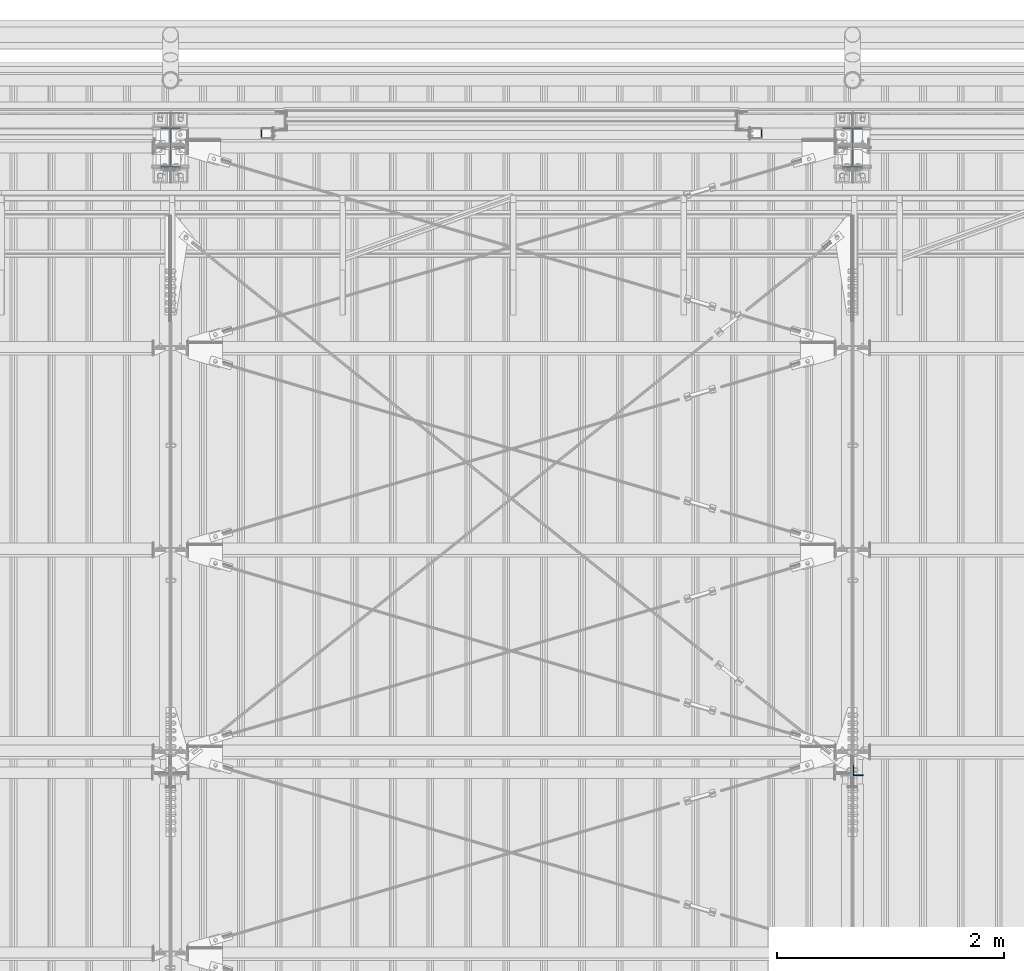
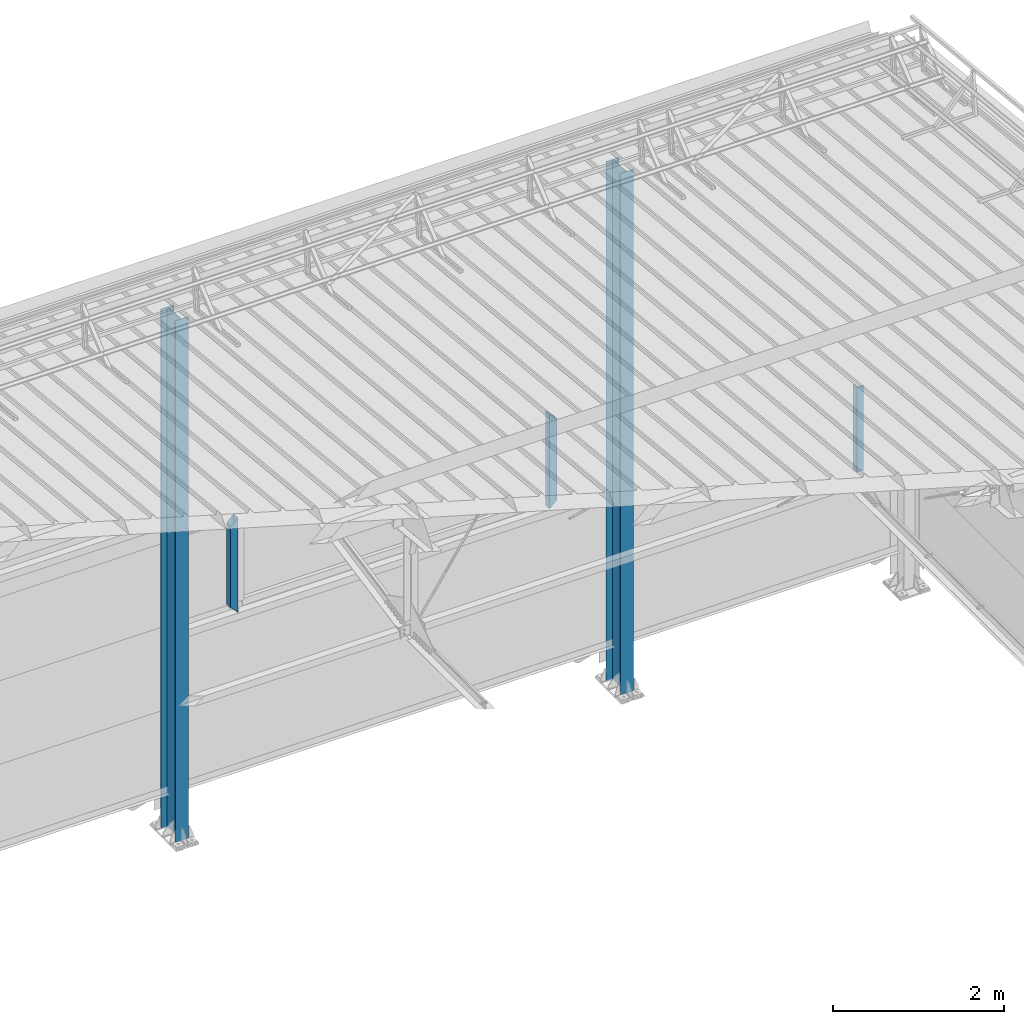
# One storey, part 238 of 709: 5 columns, 5 elements without a shape of their own.
"""IFC4 building model written with IfcOpenShell, lengths in millimetres."""

import ifcopenshell
import ifcopenshell.guid

model = None  # the IFC model being written
_history = None  # IfcOwnerHistory: only IFC2X3 demands one
_inside = {}  # id of a spatial element -> (the spatial element, [elements in it])
_under = {}  # id of a project, library or spatial element -> (it, [spatial elements below it])
_declared = {}  # id of a project -> (the project, [libraries it declares])
_typed = {}  # id of a type object -> (the type object, [elements of that type])
_made_of = {}  # id of a material, layer set ... -> (it, [elements and type objects made of it])


def new_model(schema):
    """Start an empty IFC model of exactly this schema.

    Asked for "IFC4X3", IfcOpenShell would pick the latest addendum, in which some entities
    have other attributes; the version numbers below select the first issue.
    IFC2X3 requires an IfcOwnerHistory on every rooted entity: one is made here for all.
    """
    global model, _history
    if schema == "IFC4X3":
        model = ifcopenshell.file(schema_version=(4, 3, 0, 0))
    else:
        model = ifcopenshell.file(schema=schema)
    _inside.clear()
    _under.clear()
    _declared.clear()
    _typed.clear()
    _made_of.clear()
    _history = None
    if model.schema == "IFC2X3":
        org = make("IfcOrganization", Name="unknown")
        user = make(
            "IfcPersonAndOrganization",
            ThePerson=make("IfcPerson", FamilyName="unknown"),
            TheOrganization=org,
        )
        app = make(
            "IfcApplication",
            ApplicationDeveloper=org,
            Version="unknown",
            ApplicationFullName="unknown",
            ApplicationIdentifier="unknown",
        )
        _history = make(
            "IfcOwnerHistory",
            OwningUser=user,
            OwningApplication=app,
            ChangeAction="ADDED",
            CreationDate=0,
        )
    return model


def make(cls, **values):
    """One entity of the class cls with the attributes given. An attribute that is None is left unset."""
    return model.create_entity(
        cls, **{name: value for name, value in values.items() if value is not None}
    )


def rooted(cls, **values):
    """An entity with a GlobalId (a new one), such as an element, a storey or a relation."""
    return make(cls, GlobalId=ifcopenshell.guid.new(), OwnerHistory=_history, **values)


def si_unit(unit_type, name, prefix=None):
    """IfcSIUnit, for example si_unit("LENGTHUNIT", "METRE", prefix="MILLI")."""
    return make("IfcSIUnit", UnitType=unit_type, Prefix=prefix, Name=name)


def assignment(units):
    """IfcUnitAssignment: the units of a project."""
    return None if units is None else make("IfcUnitAssignment", Units=units)


def point(xyz):
    """IfcCartesianPoint."""
    return None if xyz is None else make("IfcCartesianPoint", Coordinates=xyz)


def direction(xyz):
    """IfcDirection."""
    return None if xyz is None else make("IfcDirection", DirectionRatios=xyz)


def frame(location, z_axis=None, x_axis=None):
    """IfcAxis2Placement3D, a coordinate frame: its origin and axes. An axis left out is left unset."""
    return make(
        "IfcAxis2Placement3D",
        Location=point(location),
        Axis=direction(z_axis),
        RefDirection=direction(x_axis),
    )


def origin_with_axes():
    """The frame at (0, 0, 0) with the z axis (0, 0, 1) and the x axis (1, 0, 0) written out."""
    return frame((0.0, 0.0, 0.0), z_axis=(0.0, 0.0, 1.0), x_axis=(1.0, 0.0, 0.0))


def place(relative_to, where):
    """IfcLocalPlacement: puts the frame where relative to a parent placement (None: the world)."""
    return make(
        "IfcLocalPlacement", PlacementRelTo=relative_to, RelativePlacement=where
    )


def context(
    kind, dimensions, precision=None, world=None, true_north=None, identifier=None
):
    """IfcGeometricRepresentationContext, for example the 3D "Model" context."""
    return make(
        "IfcGeometricRepresentationContext",
        ContextIdentifier=identifier,
        ContextType=kind,
        CoordinateSpaceDimension=dimensions,
        Precision=precision,
        WorldCoordinateSystem=world,
        TrueNorth=true_north,
    )


def subcontext(parent, identifier, kind, view, scale=None):
    """IfcGeometricRepresentationSubContext, for example "Body" below "Model"."""
    return make(
        "IfcGeometricRepresentationSubContext",
        ContextIdentifier=identifier,
        ContextType=kind,
        ParentContext=parent,
        TargetScale=scale,
        TargetView=view,
    )


def project(units=None, contexts=None):
    """IfcProject with its units and contexts."""
    return rooted(
        "IfcProject",
        Name="project",
        RepresentationContexts=contexts,
        UnitsInContext=assignment(units),
    )


def spatial(cls, under=None, at=None, **own):
    """A site, building, storey or space (cls), placed at a placement, below another one or the project."""
    s = rooted(cls, ObjectPlacement=at, **own)
    if under is not None:
        _under.setdefault(under.id(), (under, []))[1].append(s)
    return s


def point_list(points):
    """IfcCartesianPointList2D or 3D."""
    cls = (
        "IfcCartesianPointList2D" if len(points[0]) == 2 else "IfcCartesianPointList3D"
    )
    return make(cls, CoordList=points)


def polygons(points, faces, closed=None, point_numbers=None):
    """IfcPolygonalFaceSet: a face is its outer loop, then its inner loops; points numbered from 1."""
    made = []
    for loops in faces:
        if len(loops) == 1:
            made.append(make("IfcIndexedPolygonalFace", CoordIndex=loops[0]))
        else:
            made.append(
                make(
                    "IfcIndexedPolygonalFaceWithVoids",
                    CoordIndex=loops[0],
                    InnerCoordIndices=loops[1:],
                )
            )
    return make(
        "IfcPolygonalFaceSet",
        Coordinates=point_list(points),
        Closed=closed,
        Faces=made,
        PnIndex=point_numbers,
    )


def shape(context_of_items, identifier, shape_type, items):
    """IfcShapeRepresentation: the items that make up one representation, for example the "Body"."""
    return make(
        "IfcShapeRepresentation",
        ContextOfItems=context_of_items,
        RepresentationIdentifier=identifier,
        RepresentationType=shape_type,
        Items=items,
    )


def material(Name=None, Category=None):
    """IfcMaterial."""
    return make("IfcMaterial", Name=Name, Category=Category)


def made_of(thing, what):
    """Note that an element or type object is made of a material, layer set ...; save() writes the relation."""
    if what is not None:
        _made_of.setdefault(what.id(), (what, []))[1].append(thing)
    return thing


def element(
    cls,
    number,
    at=None,
    inside=None,
    cuts=None,
    type_object=None,
    material=None,
    context=None,
    identifier="Body",
    shape_type=None,
    held_by="IfcProductDefinitionShape",
    body=None,
    shapes=None,
    **own,
):
    """One element of the class cls, such as IfcWall. Its Tag is "e" and its number.

    at: its placement. inside: the storey or other place that contains it. cuts: it is an
    opening in that element (IfcRelVoidsElement). A single representation is given by context,
    identifier, shape_type and body (its items); several are given by shapes. held_by: the class
    of the entity that holds the representations. save() writes the other relations.
    """
    e = rooted(cls, Tag="e%d" % number, ObjectPlacement=at, **own)
    if body is not None:
        shapes = [shape(context, identifier, shape_type, body)]
    if shapes is not None:
        e.Representation = make(held_by, Representations=shapes)
    if inside is not None:
        _inside.setdefault(inside.id(), (inside, []))[1].append(e)
    if cuts is not None:
        rooted(
            "IfcRelVoidsElement", RelatingBuildingElement=cuts, RelatedOpeningElement=e
        )
    if type_object is not None:
        _typed.setdefault(type_object.id(), (type_object, []))[1].append(e)
    return made_of(e, material)


def aggregate(whole, parts):
    """IfcRelAggregates: a whole, such as a stair, and the parts it consists of."""
    return rooted("IfcRelAggregates", RelatingObject=whole, RelatedObjects=parts)


def save(model, path):
    """Write the relations noted so far, then the file.

    IfcRelAggregates (storeys below a building ...), IfcRelContainedInSpatialStructure (elements
    in a storey), IfcRelDefinesByType, IfcRelAssociatesMaterial and IfcRelDeclares: one each for
    every whole, place, type object, material and project.
    """
    for whole, parts in _under.values():
        aggregate(whole, parts)
    for where, things in _inside.values():
        rooted(
            "IfcRelContainedInSpatialStructure",
            RelatedElements=things,
            RelatingStructure=where,
        )
    for kind, things in _typed.values():
        rooted("IfcRelDefinesByType", RelatedObjects=things, RelatingType=kind)
    for what, things in _made_of.values():
        rooted("IfcRelAssociatesMaterial", RelatedObjects=things, RelatingMaterial=what)
    for by, libraries in _declared.values():
        rooted("IfcRelDeclares", RelatingContext=by, RelatedDefinitions=libraries)
    model.write(path)


model = new_model("IFC4")

# Units and contexts
model_context = context("Model", 3, precision=0.2, world=origin_with_axes(), true_north=direction((0.0, 1.0)))
body_context = subcontext(model_context, "Body", "Model", "MODEL_VIEW")
ifc_project = project(units=[si_unit("LENGTHUNIT", "METRE", prefix="MILLI"), si_unit("AREAUNIT", "SQUARE_METRE"), si_unit("VOLUMEUNIT", "CUBIC_METRE"), si_unit("MASSUNIT", "GRAM", prefix="KILO"), si_unit("TIMEUNIT", "SECOND"), si_unit("PLANEANGLEUNIT", "RADIAN"), si_unit("SOLIDANGLEUNIT", "STERADIAN"), si_unit("THERMODYNAMICTEMPERATUREUNIT", "DEGREE_CELSIUS"), si_unit("LUMINOUSINTENSITYUNIT", "LUMEN")], contexts=[model_context])

# Site, building, storey
site_placement = place(None, origin_with_axes())
site = spatial("IfcSite", under=ifc_project, at=site_placement, CompositionType="ELEMENT")
building_placement = place(site_placement, origin_with_axes())
building = spatial("IfcBuilding", under=site, at=building_placement, Name="Undefined", CompositionType="ELEMENT")
storey_placement = place(building_placement, origin_with_axes())
storey = spatial("IfcBuildingStorey", under=building, at=storey_placement, Name="Undefined", CompositionType="ELEMENT", Elevation=0.0)

# Assembly, column
assembly_1_placement = place(storey_placement, frame((40000.0, 21827.0, -200.0), z_axis=(-1.0, 0.0, 0.0), x_axis=(0.0, 0.0, 1.0)))
assembly_1 = element("IfcElementAssembly", 1, at=assembly_1_placement, inside=storey)
ifc_material_1 = material(Name="C355-5", Category="STEEL")
column_1_placement = place(assembly_1_placement, origin_with_axes())
column_1 = element("IfcColumn", 2, at=column_1_placement, material=ifc_material_1, ObjectType="413", context=body_context, shape_type="Tessellation", body=[
    polygons([(25.0, -173.0, -87.0), (25.0, -164.0, -87.0), (7454.62297, -164.0, -87.0), (7455.52297, -173.0, -87.0), (25.0, -164.0, -3.0), (7454.62297, -164.0, -3.0), (25.0, 164.0, -3.0), (7421.82297, 164.0, -3.0), (25.0, 164.0, -87.0), (7421.82297, 164.0, -87.0), (25.0, 173.0, -87.0), (7420.92297, 173.0, -87.0), (25.0, 173.0, 87.0), (7420.92297, 173.0, 87.0), (25.0, 164.0, 87.0), (7421.82297, 164.0, 87.0), (25.0, 164.0, 3.0), (7421.82297, 164.0, 3.0), (25.0, -164.0, 3.0), (7454.62297, -164.0, 3.0), (25.0, -164.0, 87.0), (7454.62297, -164.0, 87.0), (25.0, -173.0, 87.0), (7455.52297, -173.0, 87.0)], [[[1, 2, 3, 4]], [[2, 5, 6, 3]], [[5, 7, 8, 6]], [[7, 9, 10, 8]], [[9, 11, 12, 10]], [[11, 13, 14, 12]], [[13, 15, 16, 14]], [[15, 17, 18, 16]], [[17, 19, 20, 18]], [[19, 21, 22, 20]], [[21, 23, 24, 22]], [[23, 1, 4, 24]], [[6, 8, 10, 12, 14, 16, 18, 20, 22, 24, 4, 3]], [[23, 21, 19, 17, 15, 13, 11, 9, 7, 5, 2, 1]]], closed=True),
])
aggregate(assembly_1, [column_1])

assembly_2_placement = place(storey_placement, frame((46000.0, 21827.0, -200.0), z_axis=(-1.0, 0.0, 0.0), x_axis=(0.0, 0.0, 1.0)))
assembly_2 = element("IfcElementAssembly", 3, at=assembly_2_placement, inside=storey)
column_2_placement = place(assembly_2_placement, origin_with_axes())
column_2 = element("IfcColumn", 4, at=column_2_placement, material=ifc_material_1, ObjectType="413", context=body_context, shape_type="Tessellation", body=[
    polygons([(25.0, -173.0, -87.0), (25.0, -164.0, -87.0), (7454.62297, -164.0, -87.0), (7455.52297, -173.0, -87.0), (25.0, -164.0, -3.0), (7454.62297, -164.0, -3.0), (25.0, 164.0, -3.0), (7421.82297, 164.0, -3.0), (25.0, 164.0, -87.0), (7421.82297, 164.0, -87.0), (25.0, 173.0, -87.0), (7420.92297, 173.0, -87.0), (25.0, 173.0, 87.0), (7420.92297, 173.0, 87.0), (25.0, 164.0, 87.0), (7421.82297, 164.0, 87.0), (25.0, 164.0, 3.0), (7421.82297, 164.0, 3.0), (25.0, -164.0, 3.0), (7454.62297, -164.0, 3.0), (25.0, -164.0, 87.0), (7454.62297, -164.0, 87.0), (25.0, -173.0, 87.0), (7455.52297, -173.0, 87.0)], [[[1, 2, 3, 4]], [[2, 5, 6, 3]], [[5, 7, 8, 6]], [[7, 9, 10, 8]], [[9, 11, 12, 10]], [[11, 13, 14, 12]], [[13, 15, 16, 14]], [[15, 17, 18, 16]], [[17, 19, 20, 18]], [[19, 21, 22, 20]], [[21, 23, 24, 22]], [[23, 1, 4, 24]], [[6, 8, 10, 12, 14, 16, 18, 20, 22, 24, 4, 3]], [[23, 21, 19, 17, 15, 13, 11, 9, 7, 5, 2, 1]]], closed=True),
])
aggregate(assembly_2, [column_2])

assembly_3_placement = place(storey_placement, frame((46051.0, 16347.7, 6024.30002), z_axis=(0.0, 1.0, 0.0), x_axis=(0.0, 0.0, 1.0)))
assembly_3 = element("IfcElementAssembly", 5, at=assembly_3_placement, inside=storey)
ifc_material_2 = material(Name="C345-5", Category="STEEL")
column_3_placement = place(assembly_3_placement, origin_with_axes())
column_3 = element("IfcColumn", 6, at=column_3_placement, material=ifc_material_2, ObjectType="436", context=body_context, shape_type="Tessellation", body=[
    polygons([(185.7, -45.0, -45.0), (185.7, 45.0, -45.0), (1399.4109, 45.0, -45.0), (1399.4109, -45.0, -45.0), (185.7, 45.0, -39.0), (1399.4109, 45.0, -39.0), (185.7, -39.0, -39.0), (1399.4109, -39.0, -39.0), (185.7, -39.0, 45.0), (1399.4109, -39.0, 45.0), (185.7, -45.0, 45.0), (1399.4109, -45.0, 45.0)], [[[1, 2, 3, 4]], [[2, 5, 6, 3]], [[5, 7, 8, 6]], [[7, 9, 10, 8]], [[9, 11, 12, 10]], [[11, 1, 4, 12]], [[6, 8, 10, 12, 4, 3]], [[11, 9, 7, 5, 2, 1]]], closed=True),
])
aggregate(assembly_3, [column_3])

assembly_4_placement = place(storey_placement, frame((45150.0, 21950.0, 2600.0), z_axis=(-1.0, 0.0, 0.0), x_axis=(0.0, 0.0, 1.0)))
assembly_4 = element("IfcElementAssembly", 7, at=assembly_4_placement, inside=storey)
ifc_material_3 = material(Name="C355", Category="STEEL")
column_4_placement = place(assembly_4_placement, origin_with_axes())
column_4 = element("IfcColumn", 8, at=column_4_placement, material=ifc_material_3, ObjectType="493", context=body_context, shape_type="Tessellation", body=[
    polygons([(10.0, -50.0, 50.0), (110.0, -50.0, -50.0), (1260.0, -50.0, -50.0), (1360.0, -50.0, 50.0), (10.0, 50.0, 50.0), (1360.0, 50.0, 50.0), (110.0, 50.0, -50.0), (1260.0, 50.0, -50.0), (13.0, -47.0, 47.0), (13.0, 47.0, 47.0), (1357.0, 47.0, 47.0), (1357.0, -47.0, 47.0), (107.0, -47.0, -47.0), (1263.0, -47.0, -47.0), (107.0, 47.0, -47.0), (1263.0, 47.0, -47.0)], [[[1, 2, 3, 4]], [[5, 1, 4, 6]], [[7, 5, 6, 8]], [[2, 7, 8, 3]], [[1, 5, 7, 2], [9, 13, 15, 10]], [[9, 10, 11, 12]], [[13, 9, 12, 14]], [[15, 13, 14, 16]], [[10, 15, 16, 11]], [[3, 8, 6, 4], [14, 12, 11, 16]]], closed=True),
])
aggregate(assembly_4, [column_4])

assembly_5_placement = place(storey_placement, frame((40850.0, 21950.0, 2600.0), z_axis=(-1.0, 0.0, 0.0), x_axis=(0.0, 0.0, 1.0)))
assembly_5 = element("IfcElementAssembly", 9, at=assembly_5_placement, inside=storey)
column_5_placement = place(assembly_5_placement, origin_with_axes())
column_5 = element("IfcColumn", 10, at=column_5_placement, material=ifc_material_3, ObjectType="493", context=body_context, shape_type="Tessellation", body=[
    polygons([(10.0, -50.0, -50.0), (10.0, 50.0, -50.0), (1360.0, 50.0, -50.0), (1360.0, -50.0, -50.0), (110.0, -50.0, 50.0), (1260.0, -50.0, 50.0), (110.0, 50.0, 50.0), (1260.0, 50.0, 50.0), (107.0, 47.0, 47.0), (13.0, 47.0, -47.0), (1357.0, 47.0, -47.0), (1263.0, 47.0, 47.0), (107.0, -47.0, 47.0), (1263.0, -47.0, 47.0), (13.0, -47.0, -47.0), (1357.0, -47.0, -47.0)], [[[1, 2, 3, 4]], [[5, 1, 4, 6]], [[7, 5, 6, 8]], [[2, 7, 8, 3]], [[1, 5, 7, 2], [15, 10, 9, 13]], [[9, 10, 11, 12]], [[13, 9, 12, 14]], [[15, 13, 14, 16]], [[10, 15, 16, 11]], [[6, 4, 3, 8], [14, 12, 11, 16]]], closed=True),
])
aggregate(assembly_5, [column_5])

save(model, "model.ifc")
